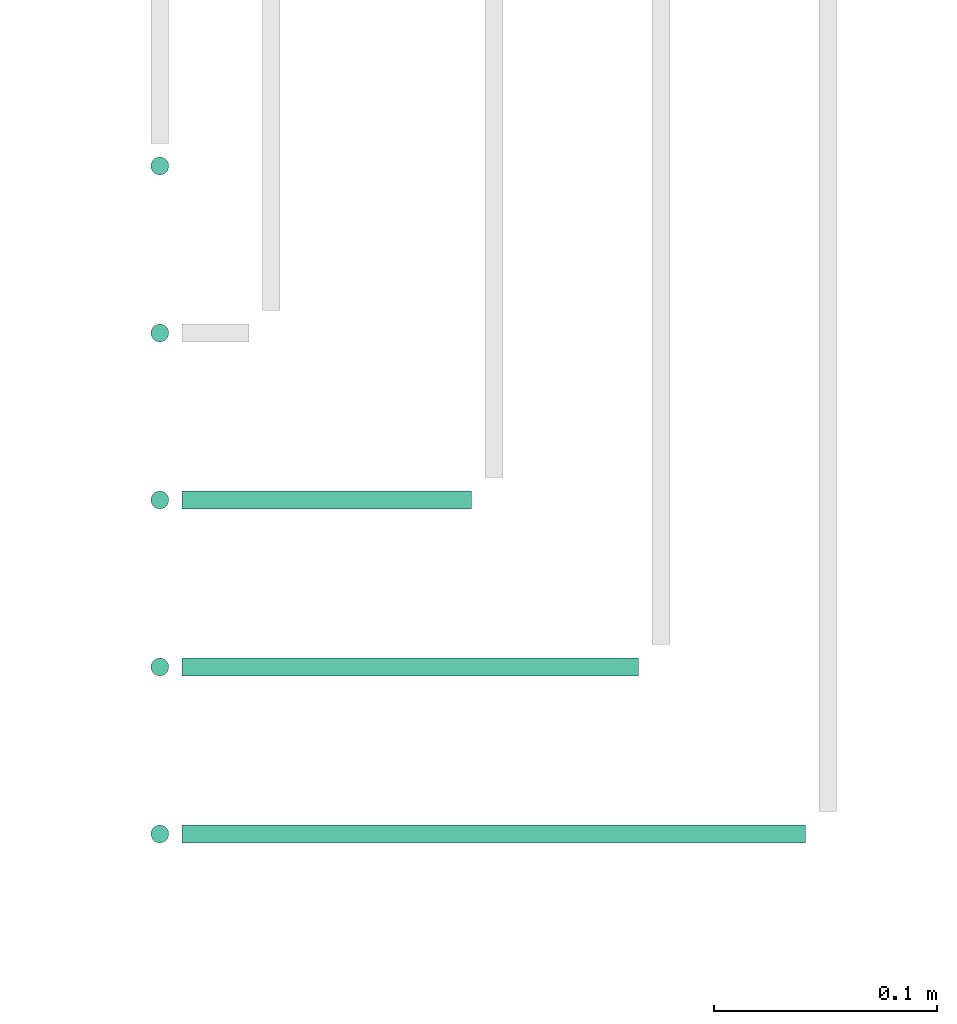
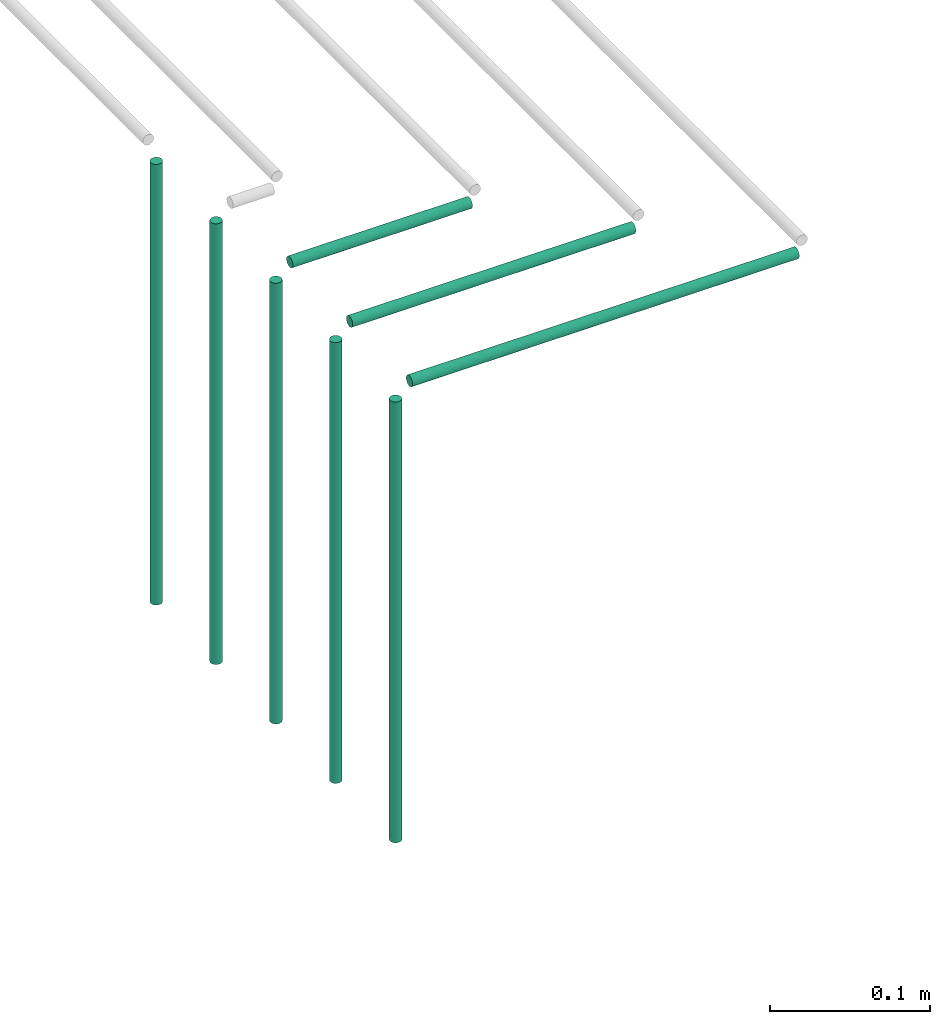
# One storey, part 56 of 89: 8 flow segments.
"""IFC2X3 building model written with IfcOpenShell, lengths in millimetres."""

from ifc_helpers import new_model, entity, si_unit, converted_unit, derived_unit, direction, frame, frame_2d, origin, origin_2d_with_axis, place, context, subcontext, project, spatial, circle, extrude, type_object, element, save


model = new_model("IFC2X3")

# Units and contexts
model_context = context("Model", 3, precision=0.01, world=origin(), true_north=direction((6.12303176911189e-17, 1.0)))
body_context = subcontext(model_context, "Body", "Model", "MODEL_VIEW")
ifc_project = project(units=[si_unit("LENGTHUNIT", "METRE", prefix="MILLI"), si_unit("AREAUNIT", "SQUARE_METRE"), si_unit("VOLUMEUNIT", "CUBIC_METRE"), converted_unit("PLANEANGLEUNIT", "DEGREE", entity("IfcRatioMeasure", 0.0174532925199433), si_unit("PLANEANGLEUNIT", "RADIAN"), dimensions=[0, 0, 0, 0, 0, 0, 0]), si_unit("MASSUNIT", "GRAM", prefix="KILO"), derived_unit("MASSDENSITYUNIT", [(si_unit("MASSUNIT", "GRAM", prefix="KILO"), 1), (si_unit("LENGTHUNIT", "METRE"), -3)]), derived_unit("MOMENTOFINERTIAUNIT", [(si_unit("LENGTHUNIT", "METRE"), 4)]), si_unit("TIMEUNIT", "SECOND"), si_unit("FREQUENCYUNIT", "HERTZ"), si_unit("THERMODYNAMICTEMPERATUREUNIT", "DEGREE_CELSIUS"), derived_unit("THERMALTRANSMITTANCEUNIT", [(si_unit("MASSUNIT", "GRAM", prefix="KILO"), 1), (si_unit("THERMODYNAMICTEMPERATUREUNIT", "KELVIN"), -1), (si_unit("TIMEUNIT", "SECOND"), -3)]), derived_unit("VOLUMETRICFLOWRATEUNIT", [(si_unit("LENGTHUNIT", "METRE"), 3), (si_unit("TIMEUNIT", "SECOND"), -1)]), derived_unit("MASSFLOWRATEUNIT", [(si_unit("MASSUNIT", "GRAM", prefix="KILO"), 1), (si_unit("TIMEUNIT", "SECOND"), -1)]), derived_unit("ROTATIONALFREQUENCYUNIT", [(si_unit("TIMEUNIT", "SECOND"), -1)]), si_unit("ELECTRICCURRENTUNIT", "AMPERE"), si_unit("ELECTRICVOLTAGEUNIT", "VOLT"), si_unit("POWERUNIT", "WATT"), si_unit("FORCEUNIT", "NEWTON", prefix="KILO"), si_unit("ILLUMINANCEUNIT", "LUX"), si_unit("LUMINOUSFLUXUNIT", "LUMEN"), si_unit("LUMINOUSINTENSITYUNIT", "CANDELA"), derived_unit("USERDEFINED", [(si_unit("MASSUNIT", "GRAM", prefix="KILO"), -1), (si_unit("LENGTHUNIT", "METRE"), -2), (si_unit("TIMEUNIT", "SECOND"), 3), (si_unit("LUMINOUSFLUXUNIT", "LUMEN"), 1)]), derived_unit("LINEARVELOCITYUNIT", [(si_unit("LENGTHUNIT", "METRE"), 1), (si_unit("TIMEUNIT", "SECOND"), -1)]), si_unit("PRESSUREUNIT", "PASCAL"), derived_unit("USERDEFINED", [(si_unit("LENGTHUNIT", "METRE"), -2), (si_unit("MASSUNIT", "GRAM", prefix="KILO"), 1), (si_unit("TIMEUNIT", "SECOND"), -2)]), derived_unit("LINEARFORCEUNIT", [(si_unit("MASSUNIT", "GRAM", prefix="KILO"), 1), (si_unit("LENGTHUNIT", "METRE"), 1), (si_unit("TIMEUNIT", "SECOND"), -2), (si_unit("LENGTHUNIT", "METRE"), -1)]), derived_unit("PLANARFORCEUNIT", [(si_unit("MASSUNIT", "GRAM", prefix="KILO"), 1), (si_unit("LENGTHUNIT", "METRE"), 1), (si_unit("TIMEUNIT", "SECOND"), -2), (si_unit("LENGTHUNIT", "METRE"), -2)])], contexts=[model_context])

# Site, building, storey
site_placement = place(None, frame((0.0, -0.00077364408347762, 0.0)))
site = spatial("IfcSite", under=ifc_project, at=site_placement, CompositionType="ELEMENT")
building_placement = place(site_placement, origin())
building = spatial("IfcBuilding", under=site, at=building_placement, CompositionType="ELEMENT")
storey_placement = place(building_placement, frame((0.0, 0.0, 24000.0)))
storey = spatial("IfcBuildingStorey", under=building, at=storey_placement, CompositionType="ELEMENT", Elevation=24000.0)

# Flow segments
pipe_segment_type = type_object("IfcPipeSegmentType", PredefinedType="NOTDEFINED")
flow_segment_1_placement = place(storey_placement, frame((58948.2301949602, 16961.4047204552, 2727.70394187732)))
element("IfcFlowSegment", 1, at=flow_segment_1_placement, inside=storey, type_object=pipe_segment_type, context=body_context, shape_type="SweptSolid", body=[
    extrude(circle(Radius=4.0, at=origin_2d_with_axis()), frame((5.59527223591499, 5.59527223591499, 0.0)), (0.0, 0.0, 1.0), 337.296058481597),
])
flow_segment_2_placement = place(storey_placement, frame((58948.2301949602, 16886.4047204552, 2727.70394187732)))
element("IfcFlowSegment", 2, at=flow_segment_2_placement, inside=storey, type_object=pipe_segment_type, context=body_context, shape_type="SweptSolid", body=[
    extrude(circle(Radius=4.0, at=origin_2d_with_axis()), frame((5.59527223591499, 5.59527223591499, 0.0)), (0.0, 0.0, 1.0), 337.296058122682),
])
flow_segment_3_placement = place(storey_placement, frame((58963.8254671961, 16811.4047204552, 3069.40472776409)))
element("IfcFlowSegment", 3, at=flow_segment_3_placement, inside=storey, type_object=pipe_segment_type, context=body_context, shape_type="SweptSolid", body=[
    extrude(circle(Radius=4.0, at=frame_2d((-2.16573425859679e-12, 0.0), x_axis=(1.0, 0.0))), frame((0.0, 5.59527223591499, 5.59527223591499), z_axis=(1.0, 0.0, 0.0), x_axis=(0.0, 1.0, 0.0)), (0.0, 0.0, 1.0), 130.016020065922),
])
flow_segment_4_placement = place(storey_placement, frame((58948.2301949602, 16811.4047204552, 2727.70394187732)))
element("IfcFlowSegment", 4, at=flow_segment_4_placement, inside=storey, type_object=pipe_segment_type, context=body_context, shape_type="SweptSolid", body=[
    extrude(circle(Radius=4.0, at=origin_2d_with_axis()), frame((5.59527223591499, 5.59527223591499, 0.0)), (0.0, 0.0, 1.0), 337.296058122682),
])
flow_segment_5_placement = place(storey_placement, frame((58963.8254671961, 16736.4047204552, 3069.40472776409)))
element("IfcFlowSegment", 5, at=flow_segment_5_placement, inside=storey, type_object=pipe_segment_type, context=body_context, shape_type="SweptSolid", body=[
    extrude(circle(Radius=4.0, at=frame_2d((-2.16573425859679e-12, 0.0), x_axis=(1.0, 0.0))), frame((0.0, 5.59527223591499, 5.59527223591499), z_axis=(1.0, 0.0, 0.0), x_axis=(0.0, 1.0, 0.0)), (0.0, 0.0, 1.0), 205.016020065922),
])
flow_segment_6_placement = place(storey_placement, frame((58948.2301949602, 16736.4047204552, 2727.70394187732)))
element("IfcFlowSegment", 6, at=flow_segment_6_placement, inside=storey, type_object=pipe_segment_type, context=body_context, shape_type="SweptSolid", body=[
    extrude(circle(Radius=4.0, at=origin_2d_with_axis()), frame((5.59527223591499, 5.59527223591499, 0.0)), (0.0, 0.0, 1.0), 337.296058122687),
])
flow_segment_7_placement = place(storey_placement, frame((58963.8254671961, 16661.4047204552, 3069.40472776409)))
element("IfcFlowSegment", 7, at=flow_segment_7_placement, inside=storey, type_object=pipe_segment_type, context=body_context, shape_type="SweptSolid", body=[
    extrude(circle(Radius=4.0, at=origin_2d_with_axis()), frame((0.0, 5.59527223591499, 5.59527223591499), z_axis=(1.0, 0.0, 0.0), x_axis=(0.0, 1.0, 0.0)), (0.0, 0.0, 1.0), 280.016020065931),
])
flow_segment_8_placement = place(storey_placement, frame((58948.2301949602, 16661.4047204552, 2727.70394187732)))
element("IfcFlowSegment", 8, at=flow_segment_8_placement, inside=storey, type_object=pipe_segment_type, context=body_context, shape_type="SweptSolid", body=[
    extrude(circle(Radius=4.0, at=origin_2d_with_axis()), frame((5.59527223591499, 5.59527223591499, 0.0)), (0.0, 0.0, 1.0), 337.296058122687),
])

save(model, "model.ifc")
